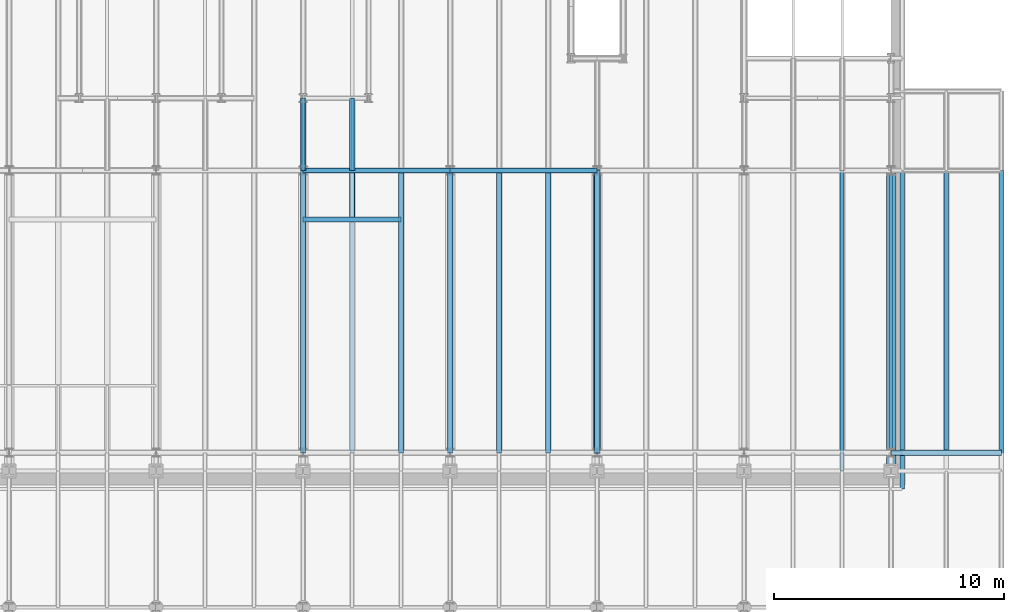
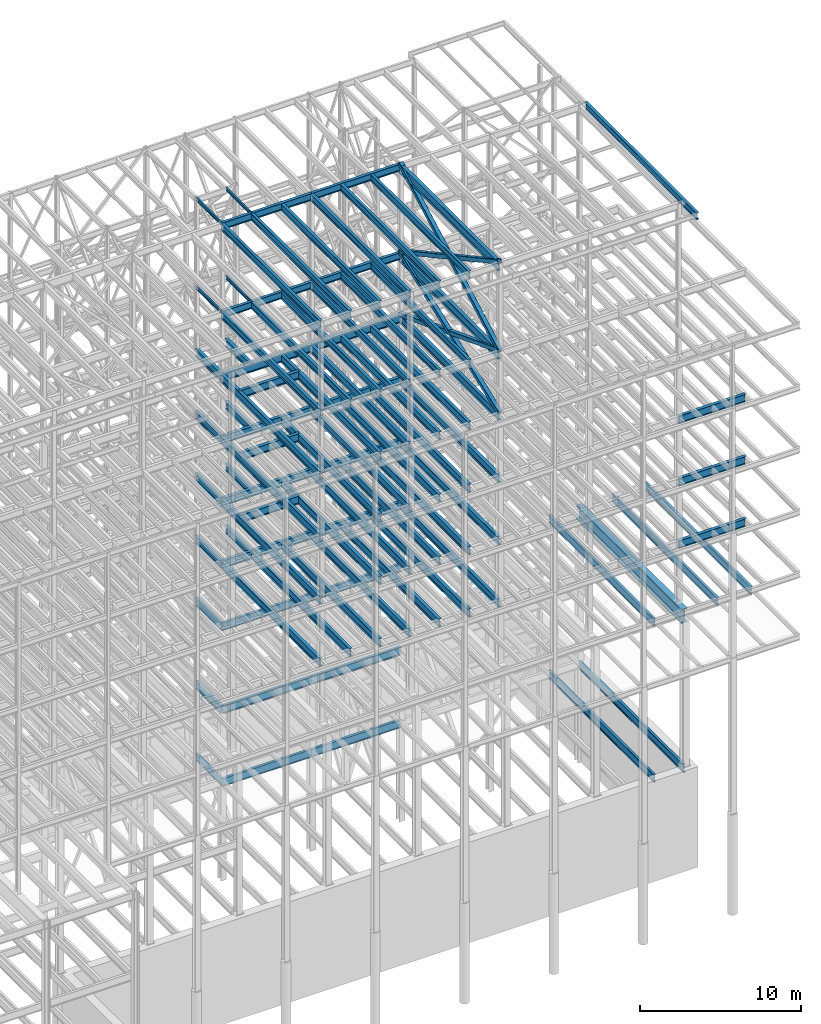
# One storey, part 140 of 150: 89 beams.
"""IFC2X3 building model written with IfcOpenShell, lengths in millimetres."""

from ifc_helpers import new_model, si_unit, frame, origin_with_axes, origin_2d_with_axis, place, context, subcontext, project, spatial, hollow_rectangle, i_section, extrude, material, type_object, element, save


model = new_model("IFC2X3")

# Units and contexts
model_context = context("Model", 3, precision=1e-05, world=origin_with_axes())
body_context = subcontext(model_context, "Body", "Model", "MODEL_VIEW")
ifc_project = project(units=[si_unit("LENGTHUNIT", "METRE", prefix="MILLI"), si_unit("AREAUNIT", "SQUARE_METRE"), si_unit("VOLUMEUNIT", "CUBIC_METRE"), si_unit("MASSUNIT", "GRAM", prefix="KILO"), si_unit("TIMEUNIT", "SECOND"), si_unit("PLANEANGLEUNIT", "RADIAN"), si_unit("SOLIDANGLEUNIT", "STERADIAN"), si_unit("THERMODYNAMICTEMPERATUREUNIT", "DEGREE_CELSIUS"), si_unit("LUMINOUSINTENSITYUNIT", "LUMEN")], contexts=[model_context])

# Site, building, storey
site_placement = place(None, origin_with_axes())
site = spatial("IfcSite", under=ifc_project, at=site_placement, CompositionType="ELEMENT")
building_placement = place(site_placement, origin_with_axes())
building = spatial("IfcBuilding", under=site, at=building_placement, Name="Undefined", CompositionType="ELEMENT")
storey_placement = place(building_placement, origin_with_axes())
storey = spatial("IfcBuildingStorey", under=building, at=storey_placement, Name="Undefined", CompositionType="ELEMENT", Elevation=0.0)

# Beams
ifc_material_1 = material()
beam_type_1 = type_object("IfcBeamType", Name="HSS12X12X1/2", PredefinedType="NOTDEFINED")
for number, where, z_axis, x_axis, name in (
    (1, (75793.6, 10185.4, 54483.0), (0.0, -0.358720539736146, 0.933445003399455), (0.0, 0.933445003399454, 0.358720539736147), "BEAM"),
    (2, (75793.6, 10185.4, 59207.4), (0.0, 0.358720539736146, 0.933445003399455), (0.0, 0.933445003399454, -0.358720539736147), "BEAM"),
):
    element("IfcBeam", number, at=place(storey_placement, frame(where, z_axis=z_axis, x_axis=x_axis)), inside=storey, type_object=beam_type_1, material=ifc_material_1, Name=name, ObjectType="HSS12X12X1/2", context=body_context, shape_type="SweptSolid", body=[
        extrude(hollow_rectangle(XDim=304.8, YDim=304.8, WallThickness=12.7, InnerFilletRadius=12.6999, OuterFilletRadius=25.3999, at=origin_2d_with_axis()), frame((13170.138811721, 0.0, 0.0), z_axis=(-1.0, 0.0, 0.0), x_axis=(0.0, -1.0, 0.0)), (0.0, 0.0, 1.0), 13170.138811721),
    ])
for number, where, z_axis, x_axis, name in (
    (3, (75793.6, 10185.4, 59207.4), (0.0, -0.478852137686944, 0.877895569092728), (0.0, 0.877895569092728, 0.478852137686943), "BEAM"),
    (4, (75793.6, 10185.4, 65913.0), (0.0, 0.478852137686944, 0.877895569092728), (0.0, 0.877895569092728, -0.478852137686943), "BEAM"),
):
    element("IfcBeam", number, at=place(storey_placement, frame(where, z_axis=z_axis, x_axis=x_axis)), inside=storey, type_object=beam_type_1, material=ifc_material_1, Name=name, ObjectType="HSS12X12X1/2", context=body_context, shape_type="SweptSolid", body=[
        extrude(hollow_rectangle(XDim=304.8, YDim=304.8, WallThickness=12.7, InnerFilletRadius=12.6999, OuterFilletRadius=25.3999, at=origin_2d_with_axis()), frame((14003.4878626719, 0.0, 7.77349732509865e-13), z_axis=(-1.0, 0.0, 0.0), x_axis=(0.0, -1.0, 0.0)), (0.0, 0.0, 1.0), 14003.4878626719),
    ])
ifc_material_2 = material(Name="STEEL/A992")
beam_type_2 = type_object("IfcBeamType", Name="W24X68", PredefinedType="NOTDEFINED")
beam_1_placement = place(storey_placement, frame((67259.2, 10185.4, 54181.375), z_axis=(0.0, 0.0, 1.0), x_axis=(0.0, 1.0, 0.0)))
element("IfcBeam", 5, at=beam_1_placement, inside=storey, type_object=beam_type_2, material=ifc_material_2, Name="BEAM", ObjectType="W24X68", context=body_context, shape_type="SweptSolid", body=[
    extrude(i_section(OverallWidth=227.838, OverallDepth=603.25, WebThickness=11.1125, FlangeThickness=14.859, FilletRadius=23.2409, at=origin_2d_with_axis()), frame((12293.6, 0.0, 0.0), z_axis=(-1.0, 0.0, 0.0), x_axis=(0.0, -1.0, 0.0)), (0.0, 0.0, 1.0), 12293.6),
])
beam_2_placement = place(storey_placement, frame((62992.0, 20345.4, 54181.375), z_axis=(0.0, 0.0, 1.0), x_axis=(1.0, 0.0, 0.0)))
element("IfcBeam", 6, at=beam_2_placement, inside=storey, type_object=beam_type_2, material=ifc_material_2, Name="BEAM", ObjectType="W24X68", context=body_context, shape_type="SweptSolid", body=[
    extrude(i_section(OverallWidth=227.838, OverallDepth=603.25, WebThickness=11.1125, FlangeThickness=14.859, FilletRadius=23.2409, at=origin_2d_with_axis()), frame((4267.20064008, 0.0, 0.0), z_axis=(-1.0, 0.0, 0.0), x_axis=(0.0, -1.0, 0.0)), (0.0, 0.0, 1.0), 4267.20064007999),
])
beam_3_placement = place(storey_placement, frame((69392.8, 22479.0, 54181.375), z_axis=(0.0, 0.0, 1.0), x_axis=(1.0, 0.0, 0.0)))
element("IfcBeam", 7, at=beam_3_placement, inside=storey, type_object=beam_type_2, material=ifc_material_2, Name="BEAM", ObjectType="W24X68", context=body_context, shape_type="SweptSolid", body=[
    extrude(i_section(OverallWidth=227.838, OverallDepth=603.25, WebThickness=11.1125, FlangeThickness=14.859, FilletRadius=23.2409, at=origin_2d_with_axis()), frame((6400.80000000001, 0.0, 0.0), z_axis=(-1.0, 0.0, 0.0), x_axis=(0.0, -1.0, 0.0)), (0.0, 0.0, 1.0), 6400.8),
])
beam_4_placement = place(storey_placement, frame((62992.0, 22479.0, 54181.375), z_axis=(0.0, 0.0, 1.0), x_axis=(1.0, 0.0, 0.0)))
element("IfcBeam", 8, at=beam_4_placement, inside=storey, type_object=beam_type_2, material=ifc_material_2, Name="BEAM", ObjectType="W24X68", context=body_context, shape_type="SweptSolid", body=[
    extrude(i_section(OverallWidth=227.838, OverallDepth=603.25, WebThickness=11.1125, FlangeThickness=14.859, FilletRadius=23.2409, at=origin_2d_with_axis()), frame((6400.79935992001, 0.0, 0.0), z_axis=(-1.0, 0.0, 0.0), x_axis=(0.0, -1.0, 0.0)), (0.0, 0.0, 1.0), 6400.79935991999),
])
for number, where, z_axis, x_axis, name in (
    (9, (62992.0, 22479.0, 54181.375), (0.0, 0.0, 1.0), (0.0, 1.0, 0.0), "BEAM"),
    (10, (65125.6, 22479.0, 54181.375), (0.0, 0.0, 1.0), (0.0, 1.0, 0.0), "BEAM"),
):
    element("IfcBeam", number, at=place(storey_placement, frame(where, z_axis=z_axis, x_axis=x_axis)), inside=storey, type_object=beam_type_2, material=ifc_material_2, Name=name, ObjectType="W24X68", context=body_context, shape_type="SweptSolid", body=[
        extrude(i_section(OverallWidth=227.838, OverallDepth=603.25, WebThickness=11.1125, FlangeThickness=14.859, FilletRadius=23.2409, at=origin_2d_with_axis()), frame((3149.59999999999, 0.0, 0.0), z_axis=(-1.0, 0.0, 0.0), x_axis=(0.0, -1.0, 0.0)), (0.0, 0.0, 1.0), 3149.6),
    ])
for number, where, z_axis, x_axis, name in (
    (11, (75793.6, 10185.4, 54181.375), (0.0, 0.0, 1.0), (0.0, 1.0, 0.0), "BEAM"),
    (12, (73660.0, 10185.4, 54181.375), (0.0, 0.0, 1.0), (0.0, 1.0, 0.0), "BEAM"),
    (13, (71526.4, 10185.4, 54181.375), (0.0, 0.0, 1.0), (0.0, 1.0, 0.0), "BEAM"),
    (14, (69392.8, 10185.4, 54181.375), (0.0, 0.0, 1.0), (0.0, 1.0, 0.0), "BEAM"),
    (15, (62992.0, 10185.4, 54181.375), (0.0, 0.0, 1.0), (0.0, 1.0, 0.0), "BEAM"),
    (16, (67259.2, 10185.4, 49456.975), (0.0, 0.0, 1.0), (0.0, 1.0, 0.0), "BEAM"),
):
    element("IfcBeam", number, at=place(storey_placement, frame(where, z_axis=z_axis, x_axis=x_axis)), inside=storey, type_object=beam_type_2, material=ifc_material_2, Name=name, ObjectType="W24X68", context=body_context, shape_type="SweptSolid", body=[
        extrude(i_section(OverallWidth=227.838, OverallDepth=603.25, WebThickness=11.1125, FlangeThickness=14.859, FilletRadius=23.2409, at=origin_2d_with_axis()), frame((12293.6, 0.0, 0.0), z_axis=(-1.0, 0.0, 0.0), x_axis=(0.0, -1.0, 0.0)), (0.0, 0.0, 1.0), 12293.6),
    ])
beam_5_placement = place(storey_placement, frame((62992.0, 20345.4, 49456.975), z_axis=(0.0, 0.0, 1.0), x_axis=(1.0, 0.0, 0.0)))
element("IfcBeam", 17, at=beam_5_placement, inside=storey, type_object=beam_type_2, material=ifc_material_2, Name="BEAM", ObjectType="W24X68", context=body_context, shape_type="SweptSolid", body=[
    extrude(i_section(OverallWidth=227.838, OverallDepth=603.25, WebThickness=11.1125, FlangeThickness=14.859, FilletRadius=23.2409, at=origin_2d_with_axis()), frame((4267.20064008, 0.0, 0.0), z_axis=(-1.0, 0.0, 0.0), x_axis=(0.0, -1.0, 0.0)), (0.0, 0.0, 1.0), 4267.20064007999),
])
beam_6_placement = place(storey_placement, frame((69392.8, 22479.0, 49456.975), z_axis=(0.0, 0.0, 1.0), x_axis=(1.0, 0.0, 0.0)))
element("IfcBeam", 18, at=beam_6_placement, inside=storey, type_object=beam_type_2, material=ifc_material_2, Name="BEAM", ObjectType="W24X68", context=body_context, shape_type="SweptSolid", body=[
    extrude(i_section(OverallWidth=227.838, OverallDepth=603.25, WebThickness=11.1125, FlangeThickness=14.859, FilletRadius=23.2409, at=origin_2d_with_axis()), frame((6400.80000000001, 0.0, 0.0), z_axis=(-1.0, 0.0, 0.0), x_axis=(0.0, -1.0, 0.0)), (0.0, 0.0, 1.0), 6400.8),
])
beam_7_placement = place(storey_placement, frame((62992.0, 22479.0, 49456.975), z_axis=(0.0, 0.0, 1.0), x_axis=(1.0, 0.0, 0.0)))
element("IfcBeam", 19, at=beam_7_placement, inside=storey, type_object=beam_type_2, material=ifc_material_2, Name="BEAM", ObjectType="W24X68", context=body_context, shape_type="SweptSolid", body=[
    extrude(i_section(OverallWidth=227.838, OverallDepth=603.25, WebThickness=11.1125, FlangeThickness=14.859, FilletRadius=23.2409, at=origin_2d_with_axis()), frame((6400.79935992001, 0.0, 0.0), z_axis=(-1.0, 0.0, 0.0), x_axis=(0.0, -1.0, 0.0)), (0.0, 0.0, 1.0), 6400.79935991999),
])
for number, where, z_axis, x_axis, name in (
    (20, (62992.0, 22479.0, 49456.975), (0.0, 0.0, 1.0), (0.0, 1.0, 0.0), "BEAM"),
    (21, (65125.6, 22479.0, 49456.975), (0.0, 0.0, 1.0), (0.0, 1.0, 0.0), "BEAM"),
):
    element("IfcBeam", number, at=place(storey_placement, frame(where, z_axis=z_axis, x_axis=x_axis)), inside=storey, type_object=beam_type_2, material=ifc_material_2, Name=name, ObjectType="W24X68", context=body_context, shape_type="SweptSolid", body=[
        extrude(i_section(OverallWidth=227.838, OverallDepth=603.25, WebThickness=11.1125, FlangeThickness=14.859, FilletRadius=23.2409, at=origin_2d_with_axis()), frame((3149.59999999999, 0.0, 0.0), z_axis=(-1.0, 0.0, 0.0), x_axis=(0.0, -1.0, 0.0)), (0.0, 0.0, 1.0), 3149.6),
    ])
beam_8_placement = place(storey_placement, frame((88595.2, 10185.4, 49456.975), z_axis=(0.0, 0.0, 1.0), x_axis=(1.0, 0.0, 0.0)))
element("IfcBeam", 22, at=beam_8_placement, inside=storey, type_object=beam_type_2, material=ifc_material_2, Name="BEAM", ObjectType="W24X68", context=body_context, shape_type="SweptSolid", body=[
    extrude(i_section(OverallWidth=227.838, OverallDepth=603.25, WebThickness=11.1125, FlangeThickness=14.859, FilletRadius=23.2409, at=origin_2d_with_axis()), frame((4800.60000000001, 0.0, 0.0), z_axis=(-1.0, 0.0, 0.0), x_axis=(0.0, -1.0, 0.0)), (0.0, 0.0, 1.0), 4800.60000000001),
])
for number, where, z_axis, x_axis, name in (
    (23, (75793.6, 10185.4, 49456.975), (0.0, 0.0, 1.0), (0.0, 1.0, 0.0), "BEAM"),
    (24, (73660.0, 10185.4, 49456.975), (0.0, 0.0, 1.0), (0.0, 1.0, 0.0), "BEAM"),
    (25, (71526.4, 10185.4, 49456.975), (0.0, 0.0, 1.0), (0.0, 1.0, 0.0), "BEAM"),
    (26, (69392.8, 10185.4, 49456.975), (0.0, 0.0, 1.0), (0.0, 1.0, 0.0), "BEAM"),
    (27, (62992.0, 10185.4, 49456.975), (0.0, 0.0, 1.0), (0.0, 1.0, 0.0), "BEAM"),
    (28, (67259.2, 10185.4, 44732.575), (0.0, 0.0, 1.0), (0.0, 1.0, 0.0), "BEAM"),
):
    element("IfcBeam", number, at=place(storey_placement, frame(where, z_axis=z_axis, x_axis=x_axis)), inside=storey, type_object=beam_type_2, material=ifc_material_2, Name=name, ObjectType="W24X68", context=body_context, shape_type="SweptSolid", body=[
        extrude(i_section(OverallWidth=227.838, OverallDepth=603.25, WebThickness=11.1125, FlangeThickness=14.859, FilletRadius=23.2409, at=origin_2d_with_axis()), frame((12293.6, 0.0, 0.0), z_axis=(-1.0, 0.0, 0.0), x_axis=(0.0, -1.0, 0.0)), (0.0, 0.0, 1.0), 12293.6),
    ])
beam_9_placement = place(storey_placement, frame((62992.0, 20345.4, 44732.575), z_axis=(0.0, 0.0, 1.0), x_axis=(1.0, 0.0, 0.0)))
element("IfcBeam", 29, at=beam_9_placement, inside=storey, type_object=beam_type_2, material=ifc_material_2, Name="BEAM", ObjectType="W24X68", context=body_context, shape_type="SweptSolid", body=[
    extrude(i_section(OverallWidth=227.838, OverallDepth=603.25, WebThickness=11.1125, FlangeThickness=14.859, FilletRadius=23.2409, at=origin_2d_with_axis()), frame((4267.20064008, 0.0, 0.0), z_axis=(-1.0, 0.0, 0.0), x_axis=(0.0, -1.0, 0.0)), (0.0, 0.0, 1.0), 4267.20064007999),
])
beam_10_placement = place(storey_placement, frame((69392.8, 22479.0, 44732.575), z_axis=(0.0, 0.0, 1.0), x_axis=(1.0, 0.0, 0.0)))
element("IfcBeam", 30, at=beam_10_placement, inside=storey, type_object=beam_type_2, material=ifc_material_2, Name="BEAM", ObjectType="W24X68", context=body_context, shape_type="SweptSolid", body=[
    extrude(i_section(OverallWidth=227.838, OverallDepth=603.25, WebThickness=11.1125, FlangeThickness=14.859, FilletRadius=23.2409, at=origin_2d_with_axis()), frame((6400.80000000001, 0.0, 0.0), z_axis=(-1.0, 0.0, 0.0), x_axis=(0.0, -1.0, 0.0)), (0.0, 0.0, 1.0), 6400.8),
])
beam_11_placement = place(storey_placement, frame((62992.0, 22479.0, 44732.575), z_axis=(0.0, 0.0, 1.0), x_axis=(1.0, 0.0, 0.0)))
element("IfcBeam", 31, at=beam_11_placement, inside=storey, type_object=beam_type_2, material=ifc_material_2, Name="BEAM", ObjectType="W24X68", context=body_context, shape_type="SweptSolid", body=[
    extrude(i_section(OverallWidth=227.838, OverallDepth=603.25, WebThickness=11.1125, FlangeThickness=14.859, FilletRadius=23.2409, at=origin_2d_with_axis()), frame((6400.79935992001, 0.0, 0.0), z_axis=(-1.0, 0.0, 0.0), x_axis=(0.0, -1.0, 0.0)), (0.0, 0.0, 1.0), 6400.79935991999),
])
for number, where, z_axis, x_axis, name in (
    (32, (62992.0, 22479.0, 44732.575), (0.0, 0.0, 1.0), (0.0, 1.0, 0.0), "BEAM"),
    (33, (65125.6, 22479.0, 44732.575), (0.0, 0.0, 1.0), (0.0, 1.0, 0.0), "BEAM"),
):
    element("IfcBeam", number, at=place(storey_placement, frame(where, z_axis=z_axis, x_axis=x_axis)), inside=storey, type_object=beam_type_2, material=ifc_material_2, Name=name, ObjectType="W24X68", context=body_context, shape_type="SweptSolid", body=[
        extrude(i_section(OverallWidth=227.838, OverallDepth=603.25, WebThickness=11.1125, FlangeThickness=14.859, FilletRadius=23.2409, at=origin_2d_with_axis()), frame((3149.59999999999, 0.0, 0.0), z_axis=(-1.0, 0.0, 0.0), x_axis=(0.0, -1.0, 0.0)), (0.0, 0.0, 1.0), 3149.6),
    ])
beam_12_placement = place(storey_placement, frame((88595.2, 10185.4, 44732.575), z_axis=(0.0, 0.0, 1.0), x_axis=(1.0, 0.0, 0.0)))
element("IfcBeam", 34, at=beam_12_placement, inside=storey, type_object=beam_type_2, material=ifc_material_2, Name="BEAM", ObjectType="W24X68", context=body_context, shape_type="SweptSolid", body=[
    extrude(i_section(OverallWidth=227.838, OverallDepth=603.25, WebThickness=11.1125, FlangeThickness=14.859, FilletRadius=23.2409, at=origin_2d_with_axis()), frame((4800.60000000001, 0.0, 0.0), z_axis=(-1.0, 0.0, 0.0), x_axis=(0.0, -1.0, 0.0)), (0.0, 0.0, 1.0), 4800.60000000001),
])
for number, where, z_axis, x_axis, name in (
    (35, (75793.6, 10185.4, 44732.575), (0.0, 0.0, 1.0), (0.0, 1.0, 0.0), "BEAM"),
    (36, (73660.0, 10185.4, 44732.575), (0.0, 0.0, 1.0), (0.0, 1.0, 0.0), "BEAM"),
    (37, (71526.4, 10185.4, 44732.575), (0.0, 0.0, 1.0), (0.0, 1.0, 0.0), "BEAM"),
    (38, (69392.8, 10185.4, 44732.575), (0.0, 0.0, 1.0), (0.0, 1.0, 0.0), "BEAM"),
    (39, (62992.0, 10185.4, 44732.575), (0.0, 0.0, 1.0), (0.0, 1.0, 0.0), "BEAM"),
):
    element("IfcBeam", number, at=place(storey_placement, frame(where, z_axis=z_axis, x_axis=x_axis)), inside=storey, type_object=beam_type_2, material=ifc_material_2, Name=name, ObjectType="W24X68", context=body_context, shape_type="SweptSolid", body=[
        extrude(i_section(OverallWidth=227.838, OverallDepth=603.25, WebThickness=11.1125, FlangeThickness=14.859, FilletRadius=23.2409, at=origin_2d_with_axis()), frame((12293.6, 0.0, 0.0), z_axis=(-1.0, 0.0, 0.0), x_axis=(0.0, -1.0, 0.0)), (0.0, 0.0, 1.0), 12293.6),
    ])
for number, where, z_axis, x_axis, name in (
    (40, (69392.8, 22479.0, 40008.175), (0.0, 0.0, 1.0), (1.0, 0.0, 0.0), "BEAM"),
    (41, (62992.0, 22479.0, 40008.175), (0.0, 0.0, 1.0), (1.0, 0.0, 0.0), "BEAM"),
):
    element("IfcBeam", number, at=place(storey_placement, frame(where, z_axis=z_axis, x_axis=x_axis)), inside=storey, type_object=beam_type_2, material=ifc_material_2, Name=name, ObjectType="W24X68", context=body_context, shape_type="SweptSolid", body=[
        extrude(i_section(OverallWidth=227.838, OverallDepth=603.25, WebThickness=11.1125, FlangeThickness=14.859, FilletRadius=23.2409, at=origin_2d_with_axis()), frame((6400.80000000001, 0.0, 0.0), z_axis=(-1.0, 0.0, 0.0), x_axis=(0.0, -1.0, 0.0)), (0.0, 0.0, 1.0), 6400.8),
    ])
for number, where, z_axis, x_axis, name in (
    (42, (62992.0, 22479.0, 40008.175), (0.0, 0.0, 1.0), (0.0, 1.0, 0.0), "BEAM"),
    (43, (65125.6, 22479.0, 40008.175), (0.0, 0.0, 1.0), (0.0, 1.0, 0.0), "BEAM"),
):
    element("IfcBeam", number, at=place(storey_placement, frame(where, z_axis=z_axis, x_axis=x_axis)), inside=storey, type_object=beam_type_2, material=ifc_material_2, Name=name, ObjectType="W24X68", context=body_context, shape_type="SweptSolid", body=[
        extrude(i_section(OverallWidth=227.838, OverallDepth=603.25, WebThickness=11.1125, FlangeThickness=14.859, FilletRadius=23.2409, at=origin_2d_with_axis()), frame((3149.59999999999, 0.0, 0.0), z_axis=(-1.0, 0.0, 0.0), x_axis=(0.0, -1.0, 0.0)), (0.0, 0.0, 1.0), 3149.6),
    ])
beam_13_placement = place(storey_placement, frame((88595.2, 10185.4, 40008.175), z_axis=(0.0, 0.0, 1.0), x_axis=(1.0, 0.0, 0.0)))
element("IfcBeam", 44, at=beam_13_placement, inside=storey, type_object=beam_type_2, material=ifc_material_2, Name="BEAM", ObjectType="W24X68", context=body_context, shape_type="SweptSolid", body=[
    extrude(i_section(OverallWidth=227.838, OverallDepth=603.25, WebThickness=11.1125, FlangeThickness=14.859, FilletRadius=23.2409, at=origin_2d_with_axis()), frame((4800.60000000001, 0.0, 0.0), z_axis=(-1.0, 0.0, 0.0), x_axis=(0.0, -1.0, 0.0)), (0.0, 0.0, 1.0), 4800.60000000001),
])
for number, where, z_axis, x_axis, name in (
    (45, (75793.6, 10185.4, 40008.175), (0.0, 0.0, 1.0), (0.0, 1.0, 0.0), "BEAM"),
    (46, (73660.0, 10185.4, 40008.175), (0.0, 0.0, 1.0), (0.0, 1.0, 0.0), "BEAM"),
    (47, (71526.4, 10185.4, 40008.175), (0.0, 0.0, 1.0), (0.0, 1.0, 0.0), "BEAM"),
    (48, (69392.8, 10185.4, 40008.175), (0.0, 0.0, 1.0), (0.0, 1.0, 0.0), "BEAM"),
    (49, (67259.2, 10185.4, 40008.175), (0.0, 0.0, 1.0), (0.0, 1.0, 0.0), "BEAM"),
    (50, (65125.6, 10185.4, 40008.175), (0.0, 0.0, 1.0), (0.0, 1.0, 0.0), "BEAM"),
    (51, (62992.0, 10185.4, 40008.175), (0.0, 0.0, 1.0), (0.0, 1.0, 0.0), "BEAM"),
):
    element("IfcBeam", number, at=place(storey_placement, frame(where, z_axis=z_axis, x_axis=x_axis)), inside=storey, type_object=beam_type_2, material=ifc_material_2, Name=name, ObjectType="W24X68", context=body_context, shape_type="SweptSolid", body=[
        extrude(i_section(OverallWidth=227.838, OverallDepth=603.25, WebThickness=11.1125, FlangeThickness=14.859, FilletRadius=23.2409, at=origin_2d_with_axis()), frame((12293.6, 0.0, 0.0), z_axis=(-1.0, 0.0, 0.0), x_axis=(0.0, -1.0, 0.0)), (0.0, 0.0, 1.0), 12293.6),
    ])
beam_14_placement = place(storey_placement, frame((69392.8, 22479.0, 28984.575), z_axis=(0.0, 0.0, 1.0), x_axis=(1.0, 0.0, 0.0)))
element("IfcBeam", 52, at=beam_14_placement, inside=storey, type_object=beam_type_2, material=ifc_material_2, Name="BEAM", ObjectType="W24X68", context=body_context, shape_type="SweptSolid", body=[
    extrude(i_section(OverallWidth=227.838, OverallDepth=603.25, WebThickness=11.1125, FlangeThickness=14.859, FilletRadius=23.2409, at=origin_2d_with_axis()), frame((6400.80000000001, 0.0, 0.0), z_axis=(-1.0, 0.0, 0.0), x_axis=(0.0, -1.0, 0.0)), (0.0, 0.0, 1.0), 6400.8),
])
beam_15_placement = place(storey_placement, frame((62992.0, 22479.0, 28984.575), z_axis=(0.0, 0.0, 1.0), x_axis=(1.0, 0.0, 0.0)))
element("IfcBeam", 53, at=beam_15_placement, inside=storey, type_object=beam_type_2, material=ifc_material_2, Name="BEAM", ObjectType="W24X68", context=body_context, shape_type="SweptSolid", body=[
    extrude(i_section(OverallWidth=227.838, OverallDepth=603.25, WebThickness=11.1125, FlangeThickness=14.859, FilletRadius=23.2409, at=origin_2d_with_axis()), frame((6400.80000000001, 0.0, 0.0), z_axis=(-1.0, 0.0, 0.0), x_axis=(0.0, -1.0, 0.0)), (0.0, 0.0, 1.0), 6400.79999999999),
])
beam_type_3 = type_object("IfcBeamType", Name="W21X55", PredefinedType="NOTDEFINED")
beam_16_placement = place(storey_placement, frame((89077.8, 8610.6, 65649.475), z_axis=(0.0, 0.0, 1.0), x_axis=(0.0, 1.0, 0.0)))
element("IfcBeam", 54, at=beam_16_placement, inside=storey, type_object=beam_type_3, material=ifc_material_2, Name="BEAM", ObjectType="W21X55", context=body_context, shape_type="SweptSolid", body=[
    extrude(i_section(OverallWidth=208.788, OverallDepth=527.05, WebThickness=9.5, FlangeThickness=13.2588, FilletRadius=16.8624, at=origin_2d_with_axis()), frame((13868.4, 0.0, 0.0), z_axis=(-1.0, 0.0, 0.0), x_axis=(0.0, -1.0, 0.0)), (0.0, 0.0, 1.0), 13868.4),
])
beam_17_placement = place(storey_placement, frame((69392.8, 22479.0, 65649.475), z_axis=(0.0, 0.0, 1.0), x_axis=(1.0, 0.0, 0.0)))
element("IfcBeam", 55, at=beam_17_placement, inside=storey, type_object=beam_type_3, material=ifc_material_2, Name="BEAM", ObjectType="W21X55", context=body_context, shape_type="SweptSolid", body=[
    extrude(i_section(OverallWidth=208.788, OverallDepth=527.05, WebThickness=9.5, FlangeThickness=13.2588, FilletRadius=16.8624, at=origin_2d_with_axis()), frame((6400.80000000001, 0.0, 0.0), z_axis=(-1.0, 0.0, 0.0), x_axis=(0.0, -1.0, 0.0)), (0.0, 0.0, 1.0), 6400.8),
])
for number, where, z_axis, x_axis, name in (
    (56, (73660.0, 10185.4, 65649.475), (0.0, 0.0, 1.0), (0.0, 1.0, 0.0), "BEAM"),
    (57, (71526.4, 10185.4, 65649.475), (0.0, 0.0, 1.0), (0.0, 1.0, 0.0), "BEAM"),
    (58, (69392.8, 10185.4, 65649.475), (0.0, 0.0, 1.0), (0.0, 1.0, 0.0), "BEAM"),
):
    element("IfcBeam", number, at=place(storey_placement, frame(where, z_axis=z_axis, x_axis=x_axis)), inside=storey, type_object=beam_type_3, material=ifc_material_2, Name=name, ObjectType="W21X55", context=body_context, shape_type="SweptSolid", body=[
        extrude(i_section(OverallWidth=208.788, OverallDepth=527.05, WebThickness=9.5, FlangeThickness=13.2588, FilletRadius=16.8624, at=origin_2d_with_axis()), frame((12293.6, 0.0, 0.0), z_axis=(-1.0, 0.0, 0.0), x_axis=(0.0, -1.0, 0.0)), (0.0, 0.0, 1.0), 12293.6),
    ])
beam_18_placement = place(storey_placement, frame((62992.0, 22479.0, 65649.475), z_axis=(0.0, 0.0, 1.0), x_axis=(1.0, 0.0, 0.0)))
element("IfcBeam", 59, at=beam_18_placement, inside=storey, type_object=beam_type_3, material=ifc_material_2, Name="BEAM", ObjectType="W21X55", context=body_context, shape_type="SweptSolid", body=[
    extrude(i_section(OverallWidth=208.788, OverallDepth=527.05, WebThickness=9.5, FlangeThickness=13.2588, FilletRadius=16.8624, at=origin_2d_with_axis()), frame((6400.79935992001, 0.0, 0.0), z_axis=(-1.0, 0.0, 0.0), x_axis=(0.0, -1.0, 0.0)), (0.0, 0.0, 1.0), 6400.79935992001),
])
for number, where, z_axis, x_axis, name in (
    (60, (67259.2, 10185.4, 65649.475), (0.0, 0.0, 1.0), (0.0, 1.0, 0.0), "BEAM"),
    (61, (65125.6, 10185.4, 65649.475), (0.0, 0.0, 1.0), (0.0, 1.0, 0.0), "BEAM"),
    (62, (62992.0, 10185.4, 65649.475), (0.0, 0.0, 1.0), (0.0, 1.0, 0.0), "BEAM"),
):
    element("IfcBeam", number, at=place(storey_placement, frame(where, z_axis=z_axis, x_axis=x_axis)), inside=storey, type_object=beam_type_3, material=ifc_material_2, Name=name, ObjectType="W21X55", context=body_context, shape_type="SweptSolid", body=[
        extrude(i_section(OverallWidth=208.788, OverallDepth=527.05, WebThickness=9.5, FlangeThickness=13.2588, FilletRadius=16.8624, at=origin_2d_with_axis()), frame((12293.6, 0.0, 0.0), z_axis=(-1.0, 0.0, 0.0), x_axis=(0.0, -1.0, 0.0)), (0.0, 0.0, 1.0), 12293.6),
    ])
beam_19_placement = place(storey_placement, frame((69392.8, 22479.0, 58943.875), z_axis=(0.0, 0.0, 1.0), x_axis=(1.0, 0.0, 0.0)))
element("IfcBeam", 63, at=beam_19_placement, inside=storey, type_object=beam_type_3, material=ifc_material_2, Name="BEAM", ObjectType="W21X55", context=body_context, shape_type="SweptSolid", body=[
    extrude(i_section(OverallWidth=208.788, OverallDepth=527.05, WebThickness=9.5, FlangeThickness=13.2588, FilletRadius=16.8624, at=origin_2d_with_axis()), frame((6400.80000000001, 0.0, 0.0), z_axis=(-1.0, 0.0, 0.0), x_axis=(0.0, -1.0, 0.0)), (0.0, 0.0, 1.0), 6400.8),
])
for number, where, z_axis, x_axis, name in (
    (64, (73660.0, 10185.4, 58943.875), (0.0, 0.0, 1.0), (0.0, 1.0, 0.0), "BEAM"),
    (65, (71526.4, 10185.4, 58943.875), (0.0, 0.0, 1.0), (0.0, 1.0, 0.0), "BEAM"),
    (66, (69392.8, 10185.4, 58943.875), (0.0, 0.0, 1.0), (0.0, 1.0, 0.0), "BEAM"),
):
    element("IfcBeam", number, at=place(storey_placement, frame(where, z_axis=z_axis, x_axis=x_axis)), inside=storey, type_object=beam_type_3, material=ifc_material_2, Name=name, ObjectType="W21X55", context=body_context, shape_type="SweptSolid", body=[
        extrude(i_section(OverallWidth=208.788, OverallDepth=527.05, WebThickness=9.5, FlangeThickness=13.2588, FilletRadius=16.8624, at=origin_2d_with_axis()), frame((12293.6, 0.0, 0.0), z_axis=(-1.0, 0.0, 0.0), x_axis=(0.0, -1.0, 0.0)), (0.0, 0.0, 1.0), 12293.6),
    ])
beam_20_placement = place(storey_placement, frame((62992.0, 22479.0, 58943.875), z_axis=(0.0, 0.0, 1.0), x_axis=(1.0, 0.0, 0.0)))
element("IfcBeam", 67, at=beam_20_placement, inside=storey, type_object=beam_type_3, material=ifc_material_2, Name="BEAM", ObjectType="W21X55", context=body_context, shape_type="SweptSolid", body=[
    extrude(i_section(OverallWidth=208.788, OverallDepth=527.05, WebThickness=9.5, FlangeThickness=13.2588, FilletRadius=16.8624, at=origin_2d_with_axis()), frame((6400.80000000001, 0.0, 0.0), z_axis=(-1.0, 0.0, 0.0), x_axis=(0.0, -1.0, 0.0)), (0.0, 0.0, 1.0), 6400.80000000001),
])
for number, where, z_axis, x_axis, name in (
    (68, (67259.2, 10185.4, 58943.875), (0.0, 0.0, 1.0), (0.0, 1.0, 0.0), "BEAM"),
    (69, (65125.6, 10185.4, 58943.875), (0.0, 0.0, 1.0), (0.0, 1.0, 0.0), "BEAM"),
    (70, (62992.0, 10185.4, 58943.875), (0.0, 0.0, 1.0), (0.0, 1.0, 0.0), "BEAM"),
):
    element("IfcBeam", number, at=place(storey_placement, frame(where, z_axis=z_axis, x_axis=x_axis)), inside=storey, type_object=beam_type_3, material=ifc_material_2, Name=name, ObjectType="W21X55", context=body_context, shape_type="SweptSolid", body=[
        extrude(i_section(OverallWidth=208.788, OverallDepth=527.05, WebThickness=9.5, FlangeThickness=13.2588, FilletRadius=16.8624, at=origin_2d_with_axis()), frame((12293.6, 0.0, 0.0), z_axis=(-1.0, 0.0, 0.0), x_axis=(0.0, -1.0, 0.0)), (0.0, 0.0, 1.0), 12293.6),
    ])
beam_type_4 = type_object("IfcBeamType", Name="W10X15", PredefinedType="NOTDEFINED")
for number, where, z_axis, x_axis, name in (
    (71, (65125.6, 22479.0, 65786.0), (0.0, 0.0, 1.0), (0.0, 1.0, 0.0), "BEAM"),
    (72, (62992.0, 22479.0, 65786.0), (0.0, 0.0, 1.0), (0.0, 1.0, 0.0), "BEAM"),
    (73, (65125.6, 22479.0, 59080.4), (0.0, 0.0, 1.0), (0.0, 1.0, 0.0), "BEAM"),
    (74, (62992.0, 22479.0, 59080.4), (0.0, 0.0, 1.0), (0.0, 1.0, 0.0), "BEAM"),
):
    element("IfcBeam", number, at=place(storey_placement, frame(where, z_axis=z_axis, x_axis=x_axis)), inside=storey, type_object=beam_type_4, material=ifc_material_2, Name=name, ObjectType="W10X15", context=body_context, shape_type="SweptSolid", body=[
        extrude(i_section(OverallWidth=101.6, OverallDepth=254.0, WebThickness=6.3499, FlangeThickness=6.858, FilletRadius=13.7795, at=origin_2d_with_axis()), frame((3149.59999999999, 0.0, 0.0), z_axis=(-1.0, 0.0, 0.0), x_axis=(0.0, -1.0, 0.0)), (0.0, 0.0, 1.0), 3149.6),
    ])
beam_type_5 = type_object("IfcBeamType", Name="W27X84", PredefinedType="NOTDEFINED")
for number, where, z_axis, x_axis, name in (
    (75, (75793.6, 10185.4, 65573.275), (0.0, 0.0, 1.0), (0.0, 1.0, 0.0), "BEAM"),
    (76, (75793.6, 10185.4, 58867.675), (0.0, 0.0, 1.0), (0.0, 1.0, 0.0), "BEAM"),
):
    element("IfcBeam", number, at=place(storey_placement, frame(where, z_axis=z_axis, x_axis=x_axis)), inside=storey, type_object=beam_type_5, material=ifc_material_2, Name=name, ObjectType="W27X84", context=body_context, shape_type="SweptSolid", body=[
        extrude(i_section(OverallWidth=254.0, OverallDepth=679.45, WebThickness=11.1125, FlangeThickness=16.256, FilletRadius=23.4314, at=origin_2d_with_axis()), frame((12293.6, 0.0, 0.0), z_axis=(-1.0, 0.0, 0.0), x_axis=(0.0, -1.0, 0.0)), (0.0, 0.0, 1.0), 12293.6),
    ])
beam_type_6 = type_object("IfcBeamType", Name="W24X55", PredefinedType="NOTDEFINED")
beam_21_placement = place(storey_placement, frame((62992.0, 22479.0, 28986.1625), z_axis=(0.0, 0.0, 1.0), x_axis=(0.0, 1.0, 0.0)))
element("IfcBeam", 77, at=beam_21_placement, inside=storey, type_object=beam_type_6, material=ifc_material_2, Name="BEAM", ObjectType="W24X55", context=body_context, shape_type="SweptSolid", body=[
    extrude(i_section(OverallWidth=178.054, OverallDepth=600.075, WebThickness=9.5249, FlangeThickness=12.827, FilletRadius=23.6854, at=origin_2d_with_axis()), frame((3149.59999999999, 0.0, 0.0), z_axis=(-1.0, 0.0, 0.0), x_axis=(0.0, -1.0, 0.0)), (0.0, 0.0, 1.0), 3149.59999999999),
])
beam_type_7 = type_object("IfcBeamType", Name="W21X44", PredefinedType="NOTDEFINED")
beam_22_placement = place(storey_placement, frame((62992.0, 22479.0, 23512.4625), z_axis=(0.0, 0.0, 1.0), x_axis=(0.0, 1.0, 0.0)))
element("IfcBeam", 78, at=beam_22_placement, inside=storey, type_object=beam_type_7, material=ifc_material_2, Name="BEAM", ObjectType="W21X44", context=body_context, shape_type="SweptSolid", body=[
    extrude(i_section(OverallWidth=165.1, OverallDepth=523.875, WebThickness=9.5249, FlangeThickness=11.43, FilletRadius=17.145, at=origin_2d_with_axis()), frame((3149.59968503999, 0.0, 0.0), z_axis=(-1.0, 0.0, 0.0), x_axis=(0.0, -1.0, 0.0)), (0.0, 0.0, 1.0), 3149.59968503999),
])
beam_type_8 = type_object("IfcBeamType", Name="W24X62", PredefinedType="NOTDEFINED")
beam_23_placement = place(storey_placement, frame((62992.0, 22479.0, 35283.775), z_axis=(0.0, 0.0, 1.0), x_axis=(0.0, 1.0, 0.0)))
element("IfcBeam", 79, at=beam_23_placement, inside=storey, type_object=beam_type_8, material=ifc_material_2, Name="BEAM", ObjectType="W24X62", context=body_context, shape_type="SweptSolid", body=[
    extrude(i_section(OverallWidth=177.8, OverallDepth=603.25, WebThickness=11.1125, FlangeThickness=14.986, FilletRadius=23.114, at=origin_2d_with_axis()), frame((3149.59999999999, 0.0, 0.0), z_axis=(-1.0, 0.0, 0.0), x_axis=(0.0, -1.0, 0.0)), (0.0, 0.0, 1.0), 3149.59999999999),
])
beam_24_placement = place(storey_placement, frame((93395.8, 9398.0, 35283.775), z_axis=(0.0, 0.0, 1.0), x_axis=(0.0, 1.0, 0.0)))
element("IfcBeam", 80, at=beam_24_placement, inside=storey, type_object=beam_type_8, material=ifc_material_2, Name="BEAM", ObjectType="W24X62", context=body_context, shape_type="SweptSolid", body=[
    extrude(i_section(OverallWidth=177.8, OverallDepth=603.25, WebThickness=11.1125, FlangeThickness=14.986, FilletRadius=23.114, at=origin_2d_with_axis()), frame((13081.0, 0.0, 0.0), z_axis=(-1.0, 0.0, 0.0), x_axis=(0.0, -1.0, 0.0)), (0.0, 0.0, 1.0), 13081.0),
])
for number, where, z_axis, x_axis, name in (
    (81, (69392.8, 22479.0, 35283.775), (0.0, 0.0, 1.0), (1.0, 0.0, 0.0), "BEAM"),
    (82, (62992.0, 22479.0, 35283.775), (0.0, 0.0, 1.0), (1.0, 0.0, 0.0), "BEAM"),
):
    element("IfcBeam", number, at=place(storey_placement, frame(where, z_axis=z_axis, x_axis=x_axis)), inside=storey, type_object=beam_type_8, material=ifc_material_2, Name=name, ObjectType="W24X62", context=body_context, shape_type="SweptSolid", body=[
        extrude(i_section(OverallWidth=177.8, OverallDepth=603.25, WebThickness=11.1125, FlangeThickness=14.986, FilletRadius=23.114, at=origin_2d_with_axis()), frame((6400.80000000001, 0.0, 0.0), z_axis=(-1.0, 0.0, 0.0), x_axis=(0.0, -1.0, 0.0)), (0.0, 0.0, 1.0), 6400.8),
    ])
for number, where, z_axis, x_axis, name in (
    (83, (90995.5, 9398.0, 35283.775), (0.0, 0.0, 1.0), (0.0, 1.0, 0.0), "BEAM"),
    (84, (86461.59935992, 9398.0, 35283.775), (0.0, 0.0, 1.0), (0.0, 1.0, 0.0), "BEAM"),
):
    element("IfcBeam", number, at=place(storey_placement, frame(where, z_axis=z_axis, x_axis=x_axis)), inside=storey, type_object=beam_type_8, material=ifc_material_2, Name=name, ObjectType="W24X62", context=body_context, shape_type="SweptSolid", body=[
        extrude(i_section(OverallWidth=177.8, OverallDepth=603.25, WebThickness=11.1125, FlangeThickness=14.986, FilletRadius=23.114, at=origin_2d_with_axis()), frame((13081.0, 0.0, 0.0), z_axis=(-1.0, 0.0, 0.0), x_axis=(0.0, -1.0, 0.0)), (0.0, 0.0, 1.0), 13081.0),
    ])
beam_25_placement = place(storey_placement, frame((69392.8, 22479.0, 23472.775), z_axis=(0.0, 0.0, 1.0), x_axis=(1.0, 0.0, 0.0)))
element("IfcBeam", 85, at=beam_25_placement, inside=storey, type_object=beam_type_8, material=ifc_material_2, Name="BEAM", ObjectType="W24X62", context=body_context, shape_type="SweptSolid", body=[
    extrude(i_section(OverallWidth=177.8, OverallDepth=603.25, WebThickness=11.1125, FlangeThickness=14.986, FilletRadius=23.114, at=origin_2d_with_axis()), frame((6400.80000000001, 0.0, 0.0), z_axis=(-1.0, 0.0, 0.0), x_axis=(0.0, -1.0, 0.0)), (0.0, 0.0, 1.0), 6400.8),
])
beam_26_placement = place(storey_placement, frame((62992.0, 22479.0, 23472.775), z_axis=(0.0, 0.0, 1.0), x_axis=(1.0, 0.0, 0.0)))
element("IfcBeam", 86, at=beam_26_placement, inside=storey, type_object=beam_type_8, material=ifc_material_2, Name="BEAM", ObjectType="W24X62", context=body_context, shape_type="SweptSolid", body=[
    extrude(i_section(OverallWidth=177.8, OverallDepth=603.25, WebThickness=11.1125, FlangeThickness=14.986, FilletRadius=23.114, at=origin_2d_with_axis()), frame((6400.80000000001, 0.0, 0.0), z_axis=(-1.0, 0.0, 0.0), x_axis=(0.0, -1.0, 0.0)), (0.0, 0.0, 1.0), 6400.79999999999),
])
for number, where, z_axis, x_axis, name in (
    (87, (88595.2, 9398.0, 23472.775), (0.0, 0.0, 1.0), (0.0, 1.0, 0.0), "BEAM"),
    (88, (86461.6, 9398.0, 23472.775), (0.0, 0.0, 1.0), (0.0, 1.0, 0.0), "BEAM"),
):
    element("IfcBeam", number, at=place(storey_placement, frame(where, z_axis=z_axis, x_axis=x_axis)), inside=storey, type_object=beam_type_8, material=ifc_material_2, Name=name, ObjectType="W24X62", context=body_context, shape_type="SweptSolid", body=[
        extrude(i_section(OverallWidth=177.8, OverallDepth=603.25, WebThickness=11.1125, FlangeThickness=14.986, FilletRadius=23.114, at=origin_2d_with_axis()), frame((13081.0, 0.0, 0.0), z_axis=(-1.0, 0.0, 0.0), x_axis=(0.0, -1.0, 0.0)), (0.0, 0.0, 1.0), 13081.0),
    ])
beam_type_9 = type_object("IfcBeamType", Name="W40X503", PredefinedType="NOTDEFINED")
beam_27_placement = place(storey_placement, frame((88595.2, 9398.0, 35052.0), z_axis=(0.0, 0.0, 1.0), x_axis=(0.0, 1.0, 0.0)))
element("IfcBeam", 89, at=beam_27_placement, inside=storey, type_object=beam_type_9, material=ifc_material_2, Name="BEAM", ObjectType="W40X503", context=body_context, shape_type="SweptSolid", body=[
    extrude(i_section(OverallWidth=416.56, OverallDepth=1066.8, WebThickness=39.6875, FlangeThickness=70.104, FilletRadius=31.496, at=origin_2d_with_axis()), frame((13081.0, 0.0, 0.0), z_axis=(-1.0, 0.0, 0.0), x_axis=(0.0, -1.0, 0.0)), (0.0, 0.0, 1.0), 13081.0),
])

save(model, "model.ifc")
